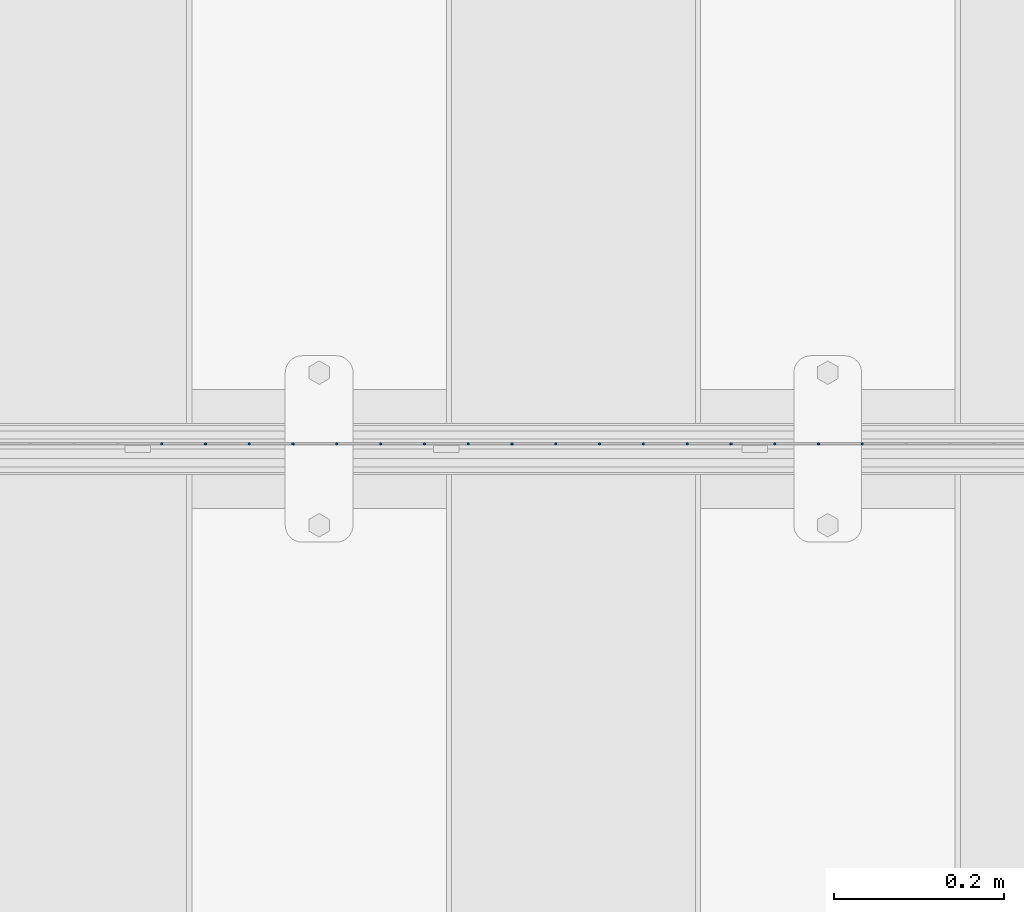
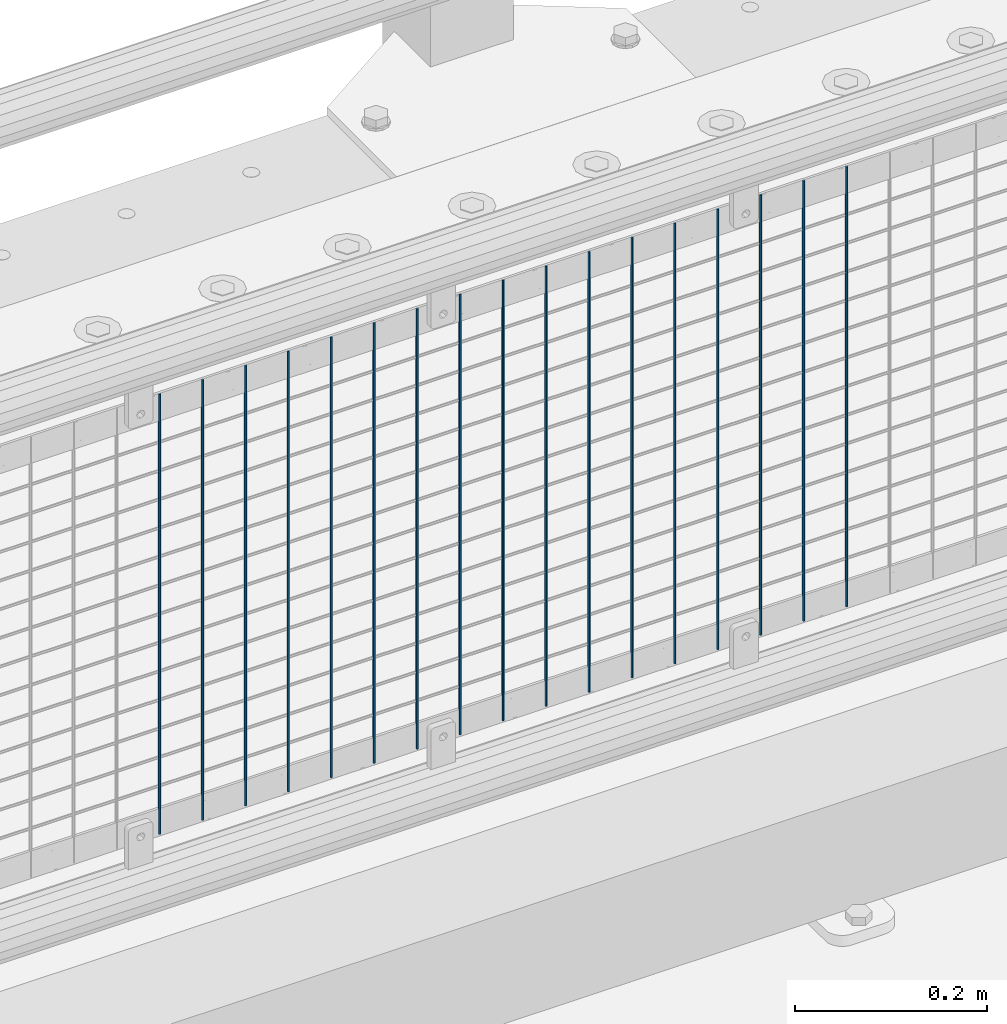
# One storey, part 53 of 193: 17 columns.
"""IFC2X3 building model written with IfcOpenShell, lengths in millimetres."""

from ifc_helpers import new_model, si_unit, frame, origin_with_axes, place, context, subcontext, project, spatial, faceted_brep, material, type_object, element, save


model = new_model("IFC2X3")

# Units and contexts
model_context = context("Model", 3, precision=1e-05, world=origin_with_axes())
body_context = subcontext(model_context, "Body", "Model", "MODEL_VIEW")
ifc_project = project(units=[si_unit("LENGTHUNIT", "METRE", prefix="MILLI"), si_unit("AREAUNIT", "SQUARE_METRE"), si_unit("VOLUMEUNIT", "CUBIC_METRE"), si_unit("MASSUNIT", "GRAM", prefix="KILO"), si_unit("TIMEUNIT", "SECOND"), si_unit("PLANEANGLEUNIT", "RADIAN"), si_unit("SOLIDANGLEUNIT", "STERADIAN"), si_unit("THERMODYNAMICTEMPERATUREUNIT", "DEGREE_CELSIUS"), si_unit("LUMINOUSINTENSITYUNIT", "LUMEN")], contexts=[model_context])

# Site, building, storey
site_placement = place(None, origin_with_axes())
site = spatial("IfcSite", under=ifc_project, at=site_placement, CompositionType="ELEMENT")
building_placement = place(site_placement, origin_with_axes())
building = spatial("IfcBuilding", under=site, at=building_placement, Name="Standard", CompositionType="ELEMENT")
storey_placement = place(building_placement, origin_with_axes())
storey = spatial("IfcBuildingStorey", under=building, at=storey_placement, Name="Undefined", CompositionType="ELEMENT", Elevation=0.0)

# Columns
ifc_material = material(Name="Misc_Undefined")
column_type = type_object("IfcColumnType", Name="D3", PredefinedType="NOTDEFINED")
for number, where, z_axis, x_axis in (
    (1, (-40509.28, 28670.5, 353.02), (-1.0, 0.0, 0.0), (0.0, 0.0, 1.0)),
    (2, (-40560.935, 28670.5, 353.02), (-1.0, 0.0, 0.0), (0.0, 0.0, 1.0)),
    (3, (-40612.59, 28670.5, 353.02), (-1.0, 0.0, 0.0), (0.0, 0.0, 1.0)),
    (4, (-40664.245, 28670.5, 353.02), (-1.0, 0.0, 0.0), (0.0, 0.0, 1.0)),
    (5, (-40715.9, 28670.5, 353.02), (-1.0, 0.0, 0.0), (0.0, 0.0, 1.0)),
    (6, (-40767.555, 28670.5, 353.02), (-1.0, 0.0, 0.0), (0.0, 0.0, 1.0)),
    (7, (-40819.21, 28670.5, 353.02), (-1.0, 0.0, 0.0), (0.0, 0.0, 1.0)),
    (8, (-40870.865, 28670.5, 353.02), (-1.0, 0.0, 0.0), (0.0, 0.0, 1.0)),
    (9, (-40922.52, 28670.5, 353.02), (-1.0, 0.0, 0.0), (0.0, 0.0, 1.0)),
    (10, (-40974.175, 28670.5, 353.02), (-1.0, 0.0, 0.0), (0.0, 0.0, 1.0)),
    (11, (-41025.83, 28670.5, 353.02), (-1.0, 0.0, 0.0), (0.0, 0.0, 1.0)),
    (12, (-41077.485, 28670.5, 353.02), (-1.0, 0.0, 0.0), (0.0, 0.0, 1.0)),
    (13, (-41129.14, 28670.5, 353.02), (-1.0, 0.0, 0.0), (0.0, 0.0, 1.0)),
    (14, (-41180.795, 28670.5, 353.02), (-1.0, 0.0, 0.0), (0.0, 0.0, 1.0)),
    (15, (-41232.45, 28670.5, 353.02), (-1.0, 0.0, 0.0), (0.0, 0.0, 1.0)),
    (16, (-41284.105, 28670.5, 353.02), (-1.0, 0.0, 0.0), (0.0, 0.0, 1.0)),
    (17, (-41335.76, 28670.5, 353.02), (-1.0, 0.0, 0.0), (0.0, 0.0, 1.0)),
):
    element("IfcColumn", number, at=place(storey_placement, frame(where, z_axis=z_axis, x_axis=x_axis)), inside=storey, type_object=column_type, material=ifc_material, ObjectType="D3", context=body_context, shape_type="Brep", body=[
        faceted_brep([(0.0, -1.49999999999636, 3.63797880709171e-12), (0.0, -0.75, -1.29903810567669), (560.0, -0.75, -1.29903810567703), (560.0, -1.5, 0.0), (0.0, 0.75, -1.29903810567669), (560.0, 0.75, -1.29903810567703), (0.0, 1.50000000000364, 7.27595761418343e-12), (560.0, 1.5, 0.0), (0.0, 0.75, 1.29903810567669), (560.0, 0.75, 1.29903810567703), (0.0, -0.75, 1.29903810567669), (560.0, -0.75, 1.29903810567703)], [[[0, 1, 2, 3]], [[1, 4, 5, 2]], [[4, 6, 7, 5]], [[6, 8, 9, 7]], [[8, 10, 11, 9]], [[10, 0, 3, 11]], [[5, 7, 9, 11, 3, 2]], [[10, 8, 6, 4, 1, 0]]]),
    ])

save(model, "model.ifc")
